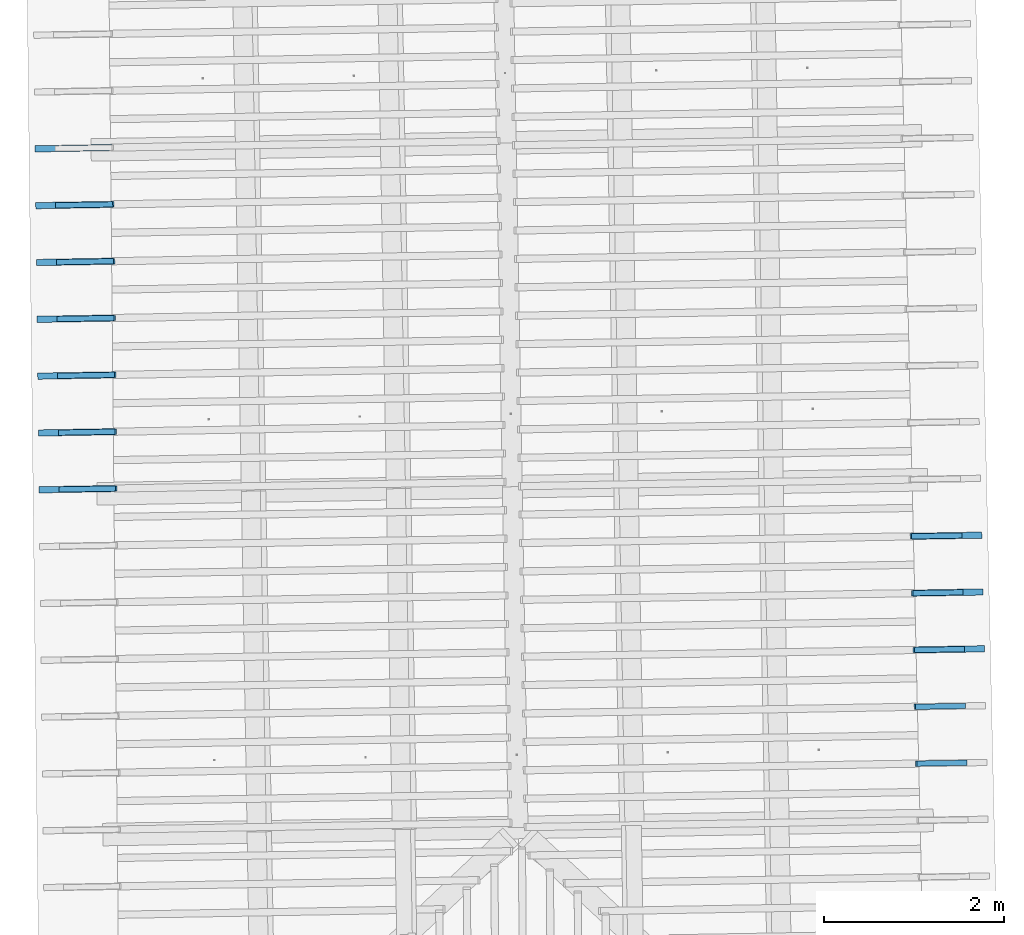
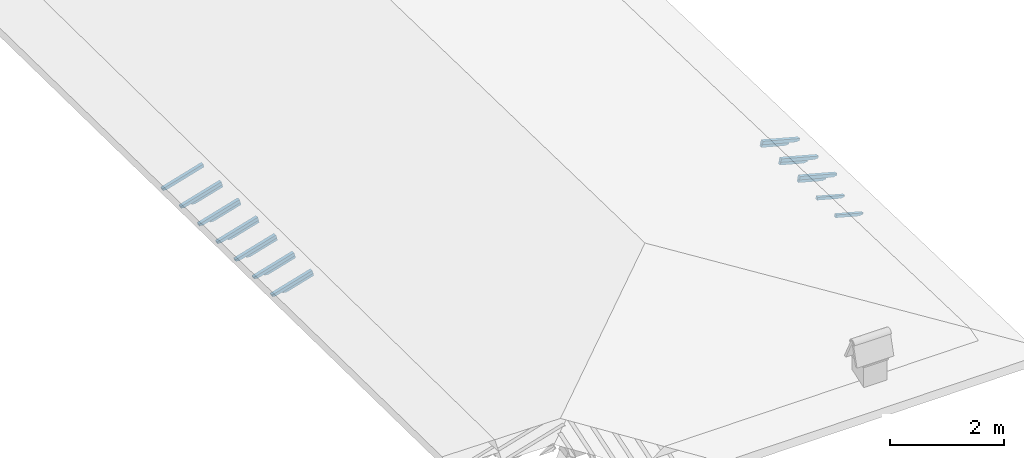
# One storey, part 12 of 19: 21 beams, 4 elements without a shape of their own.
"""IFC4 building model written with IfcOpenShell, lengths in metres."""

from ifc_helpers import new_model, entity, si_unit, converted_unit, derived_unit, direction, frame, origin, place, context, subcontext, project, spatial, line, arc, indexed_curve, outline, extrude, source, transform, mapped, material, type_object, type_shapes, element, aggregate, save


model = new_model("IFC4")

# Units and contexts
model_context = context("Model", 3, precision=1e-05, world=origin(), true_north=direction((6.123233995736766e-17, 1.0)))
body_context = subcontext(model_context, "Body", "Model", "MODEL_VIEW")
ifc_project = project(units=[si_unit("LENGTHUNIT", "METRE"), si_unit("AREAUNIT", "SQUARE_METRE"), si_unit("VOLUMEUNIT", "CUBIC_METRE"), converted_unit("PLANEANGLEUNIT", "DEGREE", entity("IfcPlaneAngleMeasure", 0.017453292519943278), si_unit("PLANEANGLEUNIT", "RADIAN"), dimensions=[0, 0, 0, 0, 0, 0, 0]), derived_unit("THERMALTRANSMITTANCEUNIT", [(si_unit("MASSUNIT", "GRAM", prefix="KILO"), 1), (si_unit("THERMODYNAMICTEMPERATUREUNIT", "KELVIN"), -1), (si_unit("TIMEUNIT", "SECOND"), -3)])], contexts=[model_context])

# Site, building, storey
site_placement = place(None, origin())
site = spatial("IfcSite", under=ifc_project, at=site_placement, CompositionType="ELEMENT")
building_placement = place(site_placement, origin())
building = spatial("IfcBuilding", under=site, at=building_placement, CompositionType="ELEMENT")
storey_placement = place(building_placement, frame((0.0, 0.0, 3.28)))
storey = spatial("IfcBuildingStorey", under=building, at=storey_placement, Name="Livello Copertura", CompositionType="ELEMENT", Elevation=3.28)

# Assembly, beams
assembly_1_placement = place(storey_placement, origin())
assembly_1 = element("IfcElementAssembly", 1, at=assembly_1_placement, inside=storey, Name="Sistema di travi strutturali:Sistema di travi strutturali", ObjectType="Sistema di travi strutturali:Sistema di travi strutturali", AssemblyPlace="NOTDEFINED", PredefinedType="BEAM_GRID")
ifc_material = material(Name="Legno - Legno da costruzione", Category="Legno")
beam_type_1 = type_object("IfcBeamType", Name="70x70:70x70", PredefinedType="JOIST", material=ifc_material)
shared_shape_1 = source(origin(), body_context, "Body", "SweptSolid", [
    extrude(outline(indexed_curve([(-0.04357142857143152, -0.5797142857142852), (0.02642857142856847, -0.5797142857142852), (0.02642857142856847, 0.18228571428571472), (0.012428571428584355, 0.18228571428571133), (0.026181867029378872, 0.20599531881361596), (0.018428571428570784, 0.23228571428571498), (0.006014118110847748, 0.2552812898006979), (0.003428571428570958, 0.2812857142857148), (-0.04357142857143152, 0.2812857142857147)], segments=[line(1, 2, 3, 4), arc(4, 5, 6), arc(6, 7, 8), line(8, 9, 1)], self_intersect=False)), frame((-0.11421428571428516, -0.03500000000000078, -0.008571428571433256), z_axis=(0.0, 1.0, 0.0), x_axis=(0.0, 0.0, -1.0)), (0.0, 0.0, 1.0), 0.06999999999999999),
])
type_shapes(beam_type_1, [shared_shape_1])
beam_1_placement = place(assembly_1_placement, frame((-5.029405355728567, 4.698225552128371, 0.10493046016911012), z_axis=(-0.2688805697492532, -0.004594467440668782, 0.9631625667976583), x_axis=(0.9630219859926786, 0.016455533263033555, 0.26891982061526515)))
beam_1 = element("IfcBeam", 2, at=beam_1_placement, type_object=beam_type_1, material=ifc_material, Name="70x70:70x70", ObjectType="70x70:70x70", PredefinedType="JOIST", context=body_context, shape_type="MappedRepresentation", body=[
    mapped(shared_shape_1, transform((0.0, 0.0, 0.0), scale=1.0)),
])
beam_type_2 = type_object("IfcBeamType", Name="70x70:70x70", PredefinedType="JOIST", material=ifc_material)
shared_shape_2 = source(origin(), body_context, "Body", "SweptSolid", [
    extrude(outline(indexed_curve([(-0.04357142857143151, -0.580428571428571), (0.026428571428568484, -0.580428571428571), (0.026428571428568484, 0.1825714285714291), (0.012428571428584384, 0.18257142857142572), (0.026181867029378903, 0.20628103309933035), (0.01842857142857075, 0.23257142857142923), (0.006014118110847714, 0.25556700408641214), (0.0034285714285709197, 0.2815714285714291), (-0.04357142857143151, 0.2815714285714291)], segments=[line(1, 2, 3, 4), arc(4, 5, 6), arc(6, 7, 8), line(8, 9, 1)], self_intersect=False)), frame((-0.11442857142857095, -0.03500000000000078, -0.008571428571433238), z_axis=(0.0, 1.0, 0.0), x_axis=(0.0, 0.0, -1.0)), (0.0, 0.0, 1.0), 0.06999999999999999),
])
type_shapes(beam_type_2, [shared_shape_2])
beam_2_placement = place(assembly_1_placement, frame((-5.0361867308732124, 5.328201642770682, 0.10604244755441838), z_axis=(-0.26888056974925356, -0.0045944674406687884, 0.9631625667976582), x_axis=(0.9630219859926786, 0.016455533263033, 0.26891982061526554)))
beam_2 = element("IfcBeam", 3, at=beam_2_placement, type_object=beam_type_2, material=ifc_material, Name="70x70:70x70", ObjectType="70x70:70x70", PredefinedType="JOIST", context=body_context, shape_type="MappedRepresentation", body=[
    mapped(shared_shape_2, transform((0.0, 0.0, 0.0), scale=1.0)),
])
beam_type_3 = type_object("IfcBeamType", Name="70x70:70x70", PredefinedType="JOIST", material=ifc_material)
shared_shape_3 = source(origin(), body_context, "Body", "SweptSolid", [
    extrude(outline(indexed_curve([(-0.04357142857143151, -0.5811428571428567), (0.026428571428568484, -0.5811428571428567), (0.026428571428568484, 0.18285714285714338), (0.012428571428584384, 0.18285714285714), (0.026181867029378903, 0.20656674738504463), (0.01842857142857075, 0.2328571428571435), (0.006014118110847714, 0.2558527183721264), (0.0034285714285709197, 0.28185714285714336), (-0.04357142857143151, 0.28185714285714336)], segments=[line(1, 2, 3, 4), arc(4, 5, 6), arc(6, 7, 8), line(8, 9, 1)], self_intersect=False)), frame((-0.11464285714285669, -0.03500000000000078, -0.008571428571433238), z_axis=(0.0, 1.0, 0.0), x_axis=(0.0, 0.0, -1.0)), (0.0, 0.0, 1.0), 0.06999999999999999),
])
type_shapes(beam_type_3, [shared_shape_3])
beam_3_placement = place(assembly_1_placement, frame((-5.042968106017856, 5.958177733412997, 0.10715443493972887), z_axis=(-0.268880569749253, -0.0045944674406687815, 0.9631625667976584), x_axis=(0.9630219859926786, 0.016455533263033662, 0.2689198206152649)))
beam_3 = element("IfcBeam", 4, at=beam_3_placement, type_object=beam_type_3, material=ifc_material, Name="70x70:70x70", ObjectType="70x70:70x70", PredefinedType="JOIST", context=body_context, shape_type="MappedRepresentation", body=[
    mapped(shared_shape_3, transform((0.0, 0.0, 0.0), scale=1.0)),
])
beam_type_4 = type_object("IfcBeamType", Name="70x70:70x70", PredefinedType="JOIST", material=ifc_material)
shared_shape_4 = source(origin(), body_context, "Body", "SweptSolid", [
    extrude(outline(indexed_curve([(-0.04357142857143144, -0.5825714285714283), (0.02642857142856855, -0.5825714285714283), (0.02642857142856855, 0.18342857142857197), (0.012428571428584454, 0.18342857142856858), (0.02618186702937897, 0.20713817595647321), (0.01842857142857058, 0.2334285714285721), (0.006014118110847545, 0.25642414694355503), (0.0034285714285707506, 0.2824285714285719), (-0.04357142857143144, 0.2824285714285719)], segments=[line(1, 2, 3, 4), arc(4, 5, 6), arc(6, 7, 8), line(8, 9, 1)], self_intersect=False)), frame((-0.11507142857142813, -0.03500000000000078, -0.00857142857143317), z_axis=(0.0, 1.0, 0.0), x_axis=(0.0, 0.0, -1.0)), (0.0, 0.0, 1.0), 0.06999999999999999),
])
type_shapes(beam_type_4, [shared_shape_4])
beam_4_placement = place(assembly_1_placement, frame((-5.049749481162497, 6.588153824055307, 0.10826642232503736), z_axis=(-0.26888056974925384, -0.0045944674406687945, 0.9631625667976582), x_axis=(0.9630219859926784, 0.016455533263033142, 0.26891982061526576)))
beam_4 = element("IfcBeam", 5, at=beam_4_placement, type_object=beam_type_4, material=ifc_material, Name="70x70:70x70", ObjectType="70x70:70x70", PredefinedType="JOIST", context=body_context, shape_type="MappedRepresentation", body=[
    mapped(shared_shape_4, transform((0.0, 0.0, 0.0), scale=1.0)),
])
beam_type_5 = type_object("IfcBeamType", Name="70x70:70x70", PredefinedType="JOIST", material=ifc_material)
shared_shape_5 = source(origin(), body_context, "Body", "SweptSolid", [
    extrude(outline(indexed_curve([(-0.04357142857143152, -0.5832857142857139), (0.026428571428568467, -0.5832857142857139), (0.026428571428568467, 0.1837142857142862), (0.012428571428584367, 0.1837142857142828), (0.026181867029378882, 0.20742389024218744), (0.018428571428570798, 0.23371428571428632), (0.006014118110847763, 0.25670986122926925), (0.0034285714285709687, 0.28271428571428614), (-0.04357142857143152, 0.28271428571428614)], segments=[line(1, 2, 3, 4), arc(4, 5, 6), arc(6, 7, 8), line(8, 9, 1)], self_intersect=False)), frame((-0.1152857142857138, -0.03500000000000078, -0.008571428571433257), z_axis=(0.0, 1.0, 0.0), x_axis=(0.0, 0.0, -1.0)), (0.0, 0.0, 1.0), 0.06999999999999999),
])
type_shapes(beam_type_5, [shared_shape_5])
beam_5_placement = place(assembly_1_placement, frame((-5.056530856307142, 7.218129914697621, 0.10937840971034651), z_axis=(-0.2688805697492532, -0.004594467440668782, 0.9631625667976583), x_axis=(0.9630219859926786, 0.016455533263033752, 0.26891982061526515)))
beam_5 = element("IfcBeam", 6, at=beam_5_placement, type_object=beam_type_5, material=ifc_material, Name="70x70:70x70", ObjectType="70x70:70x70", PredefinedType="JOIST", context=body_context, shape_type="MappedRepresentation", body=[
    mapped(shared_shape_5, transform((0.0, 0.0, 0.0), scale=1.0)),
])
beam_type_6 = type_object("IfcBeamType", Name="70x70:70x70", PredefinedType="JOIST", material=ifc_material)
shared_shape_6 = source(origin(), body_context, "Body", "SweptSolid", [
    extrude(outline(indexed_curve([(-0.043571428571431516, -0.5839999999999995), (0.026428571428568474, -0.5839999999999995), (0.026428571428568474, 0.18400000000000047), (0.012428571428584377, 0.18399999999999708), (0.026181867029378893, 0.20770960452790171), (0.018428571428570774, 0.23400000000000062), (0.006014118110847739, 0.25699557551498353), (0.0034285714285709444, 0.2830000000000004), (-0.043571428571431516, 0.2830000000000004)], segments=[line(1, 2, 3, 4), arc(4, 5, 6), arc(6, 7, 8), line(8, 9, 1)], self_intersect=False)), frame((-0.11549999999999952, -0.03500000000000078, -0.008571428571433249), z_axis=(0.0, 1.0, 0.0), x_axis=(0.0, 0.0, -1.0)), (0.0, 0.0, 1.0), 0.06999999999999999),
])
type_shapes(beam_type_6, [shared_shape_6])
beam_6_placement = place(assembly_1_placement, frame((-5.0633122314517856, 7.848106005339932, 0.11049039709565456), z_axis=(-0.26888056974925295, -0.004594467440668778, 0.9631625667976584), x_axis=(0.9630219859926787, 0.016455533263033235, 0.2689198206152649)))
beam_6 = element("IfcBeam", 7, at=beam_6_placement, type_object=beam_type_6, material=ifc_material, Name="70x70:70x70", ObjectType="70x70:70x70", PredefinedType="JOIST", context=body_context, shape_type="MappedRepresentation", body=[
    mapped(shared_shape_6, transform((0.0, 0.0, 0.0), scale=1.0)),
])
beam_type_7 = type_object("IfcBeamType", Name="70x70:70x70", PredefinedType="JOIST", material=ifc_material)
shared_shape_7 = source(origin(), body_context, "Body", "SweptSolid", [
    extrude(outline(indexed_curve([(-0.0435714285714315, -0.5847142857142853), (0.02642857142856849, -0.5847142857142853), (0.02642857142856849, 0.1842857142857148), (0.012428571428584397, 0.18428571428571142), (0.026181867029378917, 0.20799531881361605), (0.018428571428570725, 0.23428571428571493), (0.006014118110847691, 0.25728128980069787), (0.0034285714285708967, 0.28328571428571475), (-0.0435714285714315, 0.28328571428571475)], segments=[line(1, 2, 3, 4), arc(4, 5, 6), arc(6, 7, 8), line(8, 9, 1)], self_intersect=False)), frame((-0.11571428571428523, -0.03500000000000078, -0.008571428571433228), z_axis=(0.0, 1.0, 0.0), x_axis=(0.0, 0.0, -1.0)), (0.0, 0.0, 1.0), 0.06999999999999999),
])
type_shapes(beam_type_7, [shared_shape_7])
beam_7_placement = place(assembly_1_placement, frame((-5.07009360659643, 8.478082095982247, 0.11160238448096393), z_axis=(-0.2688805697492534, -0.004594467440668786, 0.9631625667976583), x_axis=(0.9630219859926785, 0.016455533263032736, 0.2689198206152653)))
beam_7 = element("IfcBeam", 8, at=beam_7_placement, type_object=beam_type_7, material=ifc_material, Name="70x70:70x70", ObjectType="70x70:70x70", PredefinedType="JOIST", context=body_context, shape_type="MappedRepresentation", body=[
    mapped(shared_shape_7, transform((0.0, 0.0, 0.0), scale=1.0)),
])
aggregate(assembly_1, [beam_1, beam_2, beam_3, beam_4, beam_5, beam_6, beam_7])

assembly_2_placement = place(storey_placement, origin())
assembly_2 = element("IfcElementAssembly", 9, at=assembly_2_placement, inside=storey, Name="Sistema di travi strutturali:Sistema di travi strutturali", ObjectType="Sistema di travi strutturali:Sistema di travi strutturali", AssemblyPlace="NOTDEFINED", PredefinedType="BEAM_GRID")
beam_type_8 = type_object("IfcBeamType", Name="60x60:60x60", PredefinedType="JOIST", material=ifc_material)
shared_shape_8 = source(origin(), body_context, "Body", "SweptSolid", [
    extrude(outline(indexed_curve([(-0.03585714285711767, -0.4284285714285716), (0.024142857142882314, -0.4284285714285716), (0.024142857142882314, 0.12357142857142843), (0.007142857142882376, 0.12357142857142843), (0.02280031419839931, 0.14116784462699616), (0.020142857142793777, 0.16457142857142956), (0.006097362558744978, 0.19272501701940936), (-0.003857142857205439, 0.2225714285714284), (-0.03585714285711767, 0.22257142857142848)], segments=[line(1, 2, 3, 4), arc(4, 5, 6), arc(6, 7, 8), line(8, 9, 1)], self_intersect=False)), frame((0.03707142857142847, -0.030000000000000786, -0.005857142857119404), z_axis=(0.0, 1.0, 0.0), x_axis=(0.0, 0.0, -1.0)), (0.0, 0.0, 1.0), 0.059999999999999984),
])
type_shapes(beam_type_8, [shared_shape_8])
beam_8_placement = place(assembly_2_placement, frame((-5.011928118694866, 4.698524192512016, 0.04232489332726197), z_axis=(-0.2688805697492532, -0.004594467440668782, 0.9631625667976583), x_axis=(0.9630219859926786, 0.016455533263033555, 0.26891982061526515)))
beam_8 = element("IfcBeam", 10, at=beam_8_placement, type_object=beam_type_8, material=ifc_material, Name="60x60:60x60", ObjectType="60x60:60x60", PredefinedType="JOIST", context=body_context, shape_type="MappedRepresentation", body=[
    mapped(shared_shape_8, transform((0.0, 0.0, 0.0), scale=1.0)),
])
beam_type_9 = type_object("IfcBeamType", Name="60x60:60x60", PredefinedType="JOIST", material=ifc_material)
shared_shape_9 = source(origin(), body_context, "Body", "SweptSolid", [
    extrude(outline(indexed_curve([(-0.03585714285711793, -0.4291428571428574), (0.02414285714288205, -0.4291428571428574), (0.02414285714288205, 0.12385714285714272), (0.007142857142882115, 0.12385714285714272), (0.022800314198399046, 0.14145355891271047), (0.02014285714279443, 0.16485714285714387), (0.00609736255874563, 0.19301073130512364), (-0.003857142857204787, 0.2228571428571427), (-0.03585714285711793, 0.22285714285714275)], segments=[line(1, 2, 3, 4), arc(4, 5, 6), arc(6, 7, 8), line(8, 9, 1)], self_intersect=False)), frame((0.03685714285714274, -0.030000000000000786, -0.005857142857119665), z_axis=(0.0, 1.0, 0.0), x_axis=(0.0, 0.0, -1.0)), (0.0, 0.0, 1.0), 0.059999999999999984),
])
type_shapes(beam_type_9, [shared_shape_9])
beam_9_placement = place(assembly_2_placement, frame((-5.01870949383951, 5.328500283154325, 0.04343688071257046), z_axis=(-0.26888056974925356, -0.0045944674406687884, 0.9631625667976582), x_axis=(0.9630219859926786, 0.016455533263033, 0.26891982061526554)))
beam_9 = element("IfcBeam", 11, at=beam_9_placement, type_object=beam_type_9, material=ifc_material, Name="60x60:60x60", ObjectType="60x60:60x60", PredefinedType="JOIST", context=body_context, shape_type="MappedRepresentation", body=[
    mapped(shared_shape_9, transform((0.0, 0.0, 0.0), scale=1.0)),
])
beam_type_10 = type_object("IfcBeamType", Name="60x60:60x60", PredefinedType="JOIST", material=ifc_material)
shared_shape_10 = source(origin(), body_context, "Body", "SweptSolid", [
    extrude(outline(indexed_curve([(-0.0358571428571179, -0.42985714285714316), (0.02414285714288208, -0.42985714285714316), (0.02414285714288208, 0.12414285714285703), (0.007142857142882144, 0.12414285714285703), (0.022800314198399077, 0.14173927319842475), (0.020142857142794356, 0.16514285714285817), (0.006097362558745559, 0.19329644559083797), (-0.0038571428572048583, 0.22314285714285698), (-0.0358571428571179, 0.22314285714285703)], segments=[line(1, 2, 3, 4), arc(4, 5, 6), arc(6, 7, 8), line(8, 9, 1)], self_intersect=False)), frame((0.03664285714285702, -0.030000000000000786, -0.005857142857119636), z_axis=(0.0, 1.0, 0.0), x_axis=(0.0, 0.0, -1.0)), (0.0, 0.0, 1.0), 0.059999999999999984),
])
type_shapes(beam_type_10, [shared_shape_10])
beam_10_placement = place(assembly_2_placement, frame((-5.025490868984154, 5.958476373796641, 0.04454886809788072), z_axis=(-0.268880569749253, -0.0045944674406687815, 0.9631625667976584), x_axis=(0.9630219859926786, 0.016455533263033662, 0.2689198206152649)))
beam_10 = element("IfcBeam", 12, at=beam_10_placement, type_object=beam_type_10, material=ifc_material, Name="60x60:60x60", ObjectType="60x60:60x60", PredefinedType="JOIST", context=body_context, shape_type="MappedRepresentation", body=[
    mapped(shared_shape_10, transform((0.0, 0.0, 0.0), scale=1.0)),
])
beam_type_11 = type_object("IfcBeamType", Name="60x60:60x60", PredefinedType="JOIST", material=ifc_material)
shared_shape_11 = source(origin(), body_context, "Body", "SweptSolid", [
    extrude(outline(indexed_curve([(-0.03585714285711788, -0.4312857142857146), (0.024142857142882102, -0.4312857142857146), (0.024142857142882102, 0.12471428571428562), (0.007142857142882163, 0.12471428571428562), (0.022800314198399098, 0.14231070176985336), (0.020142857142794308, 0.16571428571428676), (0.006097362558745509, 0.19386787416226653), (-0.0038571428572049074, 0.2237142857142856), (-0.03585714285711788, 0.22371428571428564)], segments=[line(1, 2, 3, 4), arc(4, 5, 6), arc(6, 7, 8), line(8, 9, 1)], self_intersect=False)), frame((0.036214285714285574, -0.030000000000000786, -0.005857142857119617), z_axis=(0.0, 1.0, 0.0), x_axis=(0.0, 0.0, -1.0)), (0.0, 0.0, 1.0), 0.059999999999999984),
])
type_shapes(beam_type_11, [shared_shape_11])
beam_11_placement = place(assembly_2_placement, frame((-5.032272244128797, 6.5884524644389515, 0.04566085548318943), z_axis=(-0.26888056974925384, -0.0045944674406687945, 0.9631625667976582), x_axis=(0.9630219859926784, 0.016455533263033142, 0.26891982061526576)))
beam_11 = element("IfcBeam", 13, at=beam_11_placement, type_object=beam_type_11, material=ifc_material, Name="60x60:60x60", ObjectType="60x60:60x60", PredefinedType="JOIST", context=body_context, shape_type="MappedRepresentation", body=[
    mapped(shared_shape_11, transform((0.0, 0.0, 0.0), scale=1.0)),
])
beam_type_12 = type_object("IfcBeamType", Name="60x60:60x60", PredefinedType="JOIST", material=ifc_material)
shared_shape_12 = source(origin(), body_context, "Body", "SweptSolid", [
    extrude(outline(indexed_curve([(-0.03585714285711779, -0.43200000000000016), (0.024142857142882196, -0.43200000000000016), (0.024142857142882196, 0.12499999999999985), (0.00714285714288226, 0.12499999999999985), (0.02280031419839919, 0.14259641605556758), (0.020142857142794065, 0.16600000000000098), (0.006097362558745267, 0.19415358844798075), (-0.0038571428572051493, 0.2239999999999998), (-0.03585714285711779, 0.22399999999999987)], segments=[line(1, 2, 3, 4), arc(4, 5, 6), arc(6, 7, 8), line(8, 9, 1)], self_intersect=False)), frame((0.03599999999999991, -0.030000000000000786, -0.00585714285711952), z_axis=(0.0, 1.0, 0.0), x_axis=(0.0, 0.0, -1.0)), (0.0, 0.0, 1.0), 0.059999999999999984),
])
type_shapes(beam_type_12, [shared_shape_12])
beam_12_placement = place(assembly_2_placement, frame((-5.039053619273441, 7.218428555081265, 0.04677284286849814), z_axis=(-0.2688805697492532, -0.004594467440668782, 0.9631625667976583), x_axis=(0.9630219859926786, 0.016455533263033752, 0.26891982061526515)))
beam_12 = element("IfcBeam", 14, at=beam_12_placement, type_object=beam_type_12, material=ifc_material, Name="60x60:60x60", ObjectType="60x60:60x60", PredefinedType="JOIST", context=body_context, shape_type="MappedRepresentation", body=[
    mapped(shared_shape_12, transform((0.0, 0.0, 0.0), scale=1.0)),
])
beam_type_13 = type_object("IfcBeamType", Name="60x60:60x60", PredefinedType="JOIST", material=ifc_material)
shared_shape_13 = source(origin(), body_context, "Body", "SweptSolid", [
    extrude(outline(indexed_curve([(-0.035857142857117254, -0.4327142857142859), (0.024142857142882727, -0.4327142857142859), (0.024142857142882727, 0.12528571428571422), (0.007142857142882869, 0.12528571428571428), (0.022800314198399802, 0.142882130341282), (0.0201428571427927, 0.16628571428571517), (0.006097362558743903, 0.19443930273369495), (-0.0038571428572065137, 0.224285714285714), (-0.035857142857117254, 0.2242857142857142)], segments=[line(1, 2, 3, 4), arc(4, 5, 6), arc(6, 7, 8), line(8, 9, 1)], self_intersect=False)), frame((0.03578571428571412, -0.030000000000000786, -0.00585714285711899), z_axis=(0.0, 1.0, 0.0), x_axis=(0.0, 0.0, -1.0)), (0.0, 0.0, 1.0), 0.059999999999999984),
])
type_shapes(beam_type_13, [shared_shape_13])
beam_13_placement = place(assembly_2_placement, frame((-5.045834994418086, 7.8484046457235745, 0.04788483025380619), z_axis=(-0.26888056974925295, -0.004594467440668778, 0.9631625667976584), x_axis=(0.9630219859926787, 0.016455533263033235, 0.2689198206152649)))
beam_13 = element("IfcBeam", 15, at=beam_13_placement, type_object=beam_type_13, material=ifc_material, Name="60x60:60x60", ObjectType="60x60:60x60", PredefinedType="JOIST", context=body_context, shape_type="MappedRepresentation", body=[
    mapped(shared_shape_13, transform((0.0, 0.0, 0.0), scale=1.0)),
])
aggregate(assembly_2, [beam_8, beam_9, beam_10, beam_11, beam_12, beam_13])

assembly_3_placement = place(storey_placement, origin())
assembly_3 = element("IfcElementAssembly", 16, at=assembly_3_placement, inside=storey, Name="Sistema di travi strutturali:Sistema di travi strutturali", ObjectType="Sistema di travi strutturali:Sistema di travi strutturali", AssemblyPlace="NOTDEFINED", PredefinedType="BEAM_GRID")
beam_type_14 = type_object("IfcBeamType", Name="70x70:70x70", PredefinedType="JOIST", material=ifc_material)
shared_shape_14 = source(origin(), body_context, "Body", "SweptSolid", [
    extrude(outline(indexed_curve([(-0.04357142857143146, -0.5268571428571424), (0.026428571428568533, -0.5268571428571424), (0.026428571428568533, 0.16114285714285767), (0.012428571428584436, 0.16114285714285428), (0.026181867029378955, 0.18485246167075892), (0.018428571428570614, 0.2111428571428578), (0.006014118110847579, 0.2341384326578407), (0.0034285714285707844, 0.2601428571428576), (-0.04357142857143146, 0.2601428571428576)], segments=[line(1, 2, 3, 4), arc(4, 5, 6), arc(6, 7, 8), line(8, 9, 1)], self_intersect=False)), frame((-0.09835714285714238, -0.03500000000000078, -0.008571428571433188), z_axis=(0.0, 1.0, 0.0), x_axis=(0.0, 0.0, -1.0)), (0.0, 0.0, 1.0), 0.06999999999999999),
])
type_shapes(beam_type_14, [shared_shape_14])
beam_14_placement = place(assembly_3_placement, frame((4.676467380121404, 4.183071432131907, 0.10949700717344668), z_axis=(0.2688805697492536, 0.004594467440668776, 0.9631625667976582), x_axis=(-0.9630219859926785, -0.016455533263032226, 0.2689198206152656)))
beam_14 = element("IfcBeam", 17, at=beam_14_placement, type_object=beam_type_14, material=ifc_material, Name="70x70:70x70", ObjectType="70x70:70x70", PredefinedType="JOIST", context=body_context, shape_type="MappedRepresentation", body=[
    mapped(shared_shape_14, transform((0.0, 0.0, 0.0), scale=1.0)),
])
beam_15_placement = place(assembly_3_placement, frame((4.690915386697829, 3.5532263442188956, 0.1084681201245834), z_axis=(0.26888056974925323, 0.0045944674406687685, 0.9631625667976583), x_axis=(-0.9630219859926786, -0.01645553326303236, 0.26891982061526515)))
beam_15 = element("IfcBeam", 18, at=beam_15_placement, type_object=beam_type_14, material=ifc_material, Name="70x70:70x70", ObjectType="70x70:70x70", PredefinedType="JOIST", context=body_context, shape_type="MappedRepresentation", body=[
    mapped(shared_shape_14, transform((0.0, 0.0, 0.0), scale=1.0)),
])
beam_type_15 = type_object("IfcBeamType", Name="70x70:70x70", PredefinedType="JOIST", material=ifc_material)
shared_shape_15 = source(origin(), body_context, "Body", "SweptSolid", [
    extrude(outline(indexed_curve([(-0.043571428571431446, -0.5261428571428567), (0.026428571428568543, -0.5261428571428567), (0.026428571428568543, 0.16085714285714334), (0.012428571428584447, 0.16085714285714), (0.026181867029378966, 0.18456674738504464), (0.01842857142857059, 0.2108571428571435), (0.006014118110847556, 0.2338527183721264), (0.0034285714285707614, 0.2598571428571433), (-0.043571428571431446, 0.2598571428571433)], segments=[line(1, 2, 3, 4), arc(4, 5, 6), arc(6, 7, 8), line(8, 9, 1)], self_intersect=False)), frame((-0.09814285714285666, -0.03500000000000078, -0.008571428571433178), z_axis=(0.0, 1.0, 0.0), x_axis=(0.0, 0.0, -1.0)), (0.0, 0.0, 1.0), 0.06999999999999999),
])
type_shapes(beam_type_15, [shared_shape_15])
beam_16_placement = place(assembly_3_placement, frame((4.705363393274253, 2.923381256305881, 0.10743923307571968), z_axis=(0.26888056974925295, 0.004594467440668763, 0.9631625667976584), x_axis=(-0.9630219859926787, -0.016455533263032514, 0.2689198206152649)))
beam_16 = element("IfcBeam", 19, at=beam_16_placement, type_object=beam_type_15, material=ifc_material, Name="70x70:70x70", ObjectType="70x70:70x70", PredefinedType="JOIST", context=body_context, shape_type="MappedRepresentation", body=[
    mapped(shared_shape_15, transform((0.0, 0.0, 0.0), scale=1.0)),
])
aggregate(assembly_3, [beam_14, beam_15, beam_16])

assembly_4_placement = place(storey_placement, origin())
assembly_4 = element("IfcElementAssembly", 20, at=assembly_4_placement, inside=storey, Name="Sistema di travi strutturali:Sistema di travi strutturali", ObjectType="Sistema di travi strutturali:Sistema di travi strutturali", AssemblyPlace="NOTDEFINED", PredefinedType="BEAM_GRID")
beam_type_16 = type_object("IfcBeamType", Name="60x60:60x60", PredefinedType="JOIST", material=ifc_material)
shared_shape_16 = source(origin(), body_context, "Body", "SweptSolid", [
    extrude(outline(indexed_curve([(-0.03585714285711773, -0.3755714285714287), (0.024142857142882244, -0.3755714285714287), (0.024142857142882244, 0.10242857142857129), (0.007142857142882308, 0.10242857142857129), (0.022800314198399244, 0.120024987484139), (0.020142857142793947, 0.14342857142857243), (0.006097362558745147, 0.1715821598765522), (-0.00385714285720527, 0.20142857142857126), (-0.03585714285711773, 0.20142857142857132)], segments=[line(1, 2, 3, 4), arc(4, 5, 6), arc(6, 7, 8), line(8, 9, 1)], self_intersect=False)), frame((0.0529285714285713, -0.030000000000000786, -0.005857142857119472), z_axis=(0.0, 1.0, 0.0), x_axis=(0.0, 0.0, -1.0)), (0.0, 0.0, 1.0), 0.059999999999999984),
])
type_shapes(beam_type_16, [shared_shape_16])
beam_17_placement = place(assembly_4_placement, frame((4.658990143087703, 4.182772791748264, 0.0468914403315992), z_axis=(0.2688805697492532, 0.004594467440668768, 0.9631625667976583), x_axis=(-0.9630219859926786, -0.01645553326303224, 0.2689198206152651)))
beam_17 = element("IfcBeam", 21, at=beam_17_placement, type_object=beam_type_16, material=ifc_material, Name="60x60:60x60", ObjectType="60x60:60x60", PredefinedType="JOIST", context=body_context, shape_type="MappedRepresentation", body=[
    mapped(shared_shape_16, transform((0.0, 0.0, 0.0), scale=1.0)),
])
beam_18_placement = place(assembly_4_placement, frame((4.673438149664127, 3.552927703835252, 0.04586255328273592), z_axis=(0.2688805697492534, 0.004594467440668771, 0.9631625667976584), x_axis=(-0.9630219859926786, -0.016455533263031737, 0.2689198206152653)))
beam_18 = element("IfcBeam", 22, at=beam_18_placement, type_object=beam_type_16, material=ifc_material, Name="60x60:60x60", ObjectType="60x60:60x60", PredefinedType="JOIST", context=body_context, shape_type="MappedRepresentation", body=[
    mapped(shared_shape_16, transform((0.0, 0.0, 0.0), scale=1.0)),
])
beam_type_17 = type_object("IfcBeamType", Name="60x60:60x60", PredefinedType="JOIST", material=ifc_material)
shared_shape_17 = source(origin(), body_context, "Body", "SweptSolid", [
    extrude(outline(indexed_curve([(-0.03585714285711773, -0.374857142857143), (0.024142857142882244, -0.374857142857143), (0.024142857142882244, 0.10214285714285697), (0.007142857142882308, 0.10214285714285697), (0.022800314198399244, 0.11973927319842471), (0.020142857142793947, 0.1431428571428581), (0.006097362558745147, 0.1712964455908379), (-0.00385714285720527, 0.20114285714285693), (-0.03585714285711773, 0.201142857142857)], segments=[line(1, 2, 3, 4), arc(4, 5, 6), arc(6, 7, 8), line(8, 9, 1)], self_intersect=False)), frame((0.05314285714285701, -0.030000000000000786, -0.005857142857119472), z_axis=(0.0, 1.0, 0.0), x_axis=(0.0, 0.0, -1.0)), (0.0, 0.0, 1.0), 0.059999999999999984),
])
type_shapes(beam_type_17, [shared_shape_17])
beam_19_placement = place(assembly_4_placement, frame((4.687886156240551, 2.9230826159222376, 0.04483366623387197), z_axis=(0.26888056974925295, 0.004594467440668763, 0.9631625667976584), x_axis=(-0.9630219859926787, -0.016455533263032514, 0.2689198206152649)))
beam_19 = element("IfcBeam", 23, at=beam_19_placement, type_object=beam_type_17, material=ifc_material, Name="60x60:60x60", ObjectType="60x60:60x60", PredefinedType="JOIST", context=body_context, shape_type="MappedRepresentation", body=[
    mapped(shared_shape_17, transform((0.0, 0.0, 0.0), scale=1.0)),
])
beam_type_18 = type_object("IfcBeamType", Name="60x60:60x60", PredefinedType="JOIST", material=ifc_material)
shared_shape_18 = source(origin(), body_context, "Body", "SweptSolid", [
    extrude(outline(indexed_curve([(-0.03585714285711785, -0.3741428571428572), (0.024142857142882126, -0.3741428571428572), (0.024142857142882126, 0.10185714285714267), (0.007142857142882192, 0.10185714285714267), (0.022800314198399122, 0.11945355891271041), (0.02014285714279423, 0.14285714285714382), (0.0060973625587454365, 0.1710107313051236), (-0.00385714285720498, 0.20085714285714265), (-0.03585714285711785, 0.2008571428571427)], segments=[line(1, 2, 3, 4), arc(4, 5, 6), arc(6, 7, 8), line(8, 9, 1)], self_intersect=False)), frame((0.05335714285714274, -0.030000000000000786, -0.005857142857119588), z_axis=(0.0, 1.0, 0.0), x_axis=(0.0, 0.0, -1.0)), (0.0, 0.0, 1.0), 0.059999999999999984),
])
type_shapes(beam_type_18, [shared_shape_18])
beam_20_placement = place(assembly_4_placement, frame((4.702334162816974, 2.293237528009226, 0.04380477918500825), z_axis=(0.2688805697492536, 0.004594467440668777, 0.9631625667976582), x_axis=(-0.9630219859926785, -0.01645553326303237, 0.2689198206152656)))
beam_20 = element("IfcBeam", 24, at=beam_20_placement, type_object=beam_type_18, material=ifc_material, Name="60x60:60x60", ObjectType="60x60:60x60", PredefinedType="JOIST", context=body_context, shape_type="MappedRepresentation", body=[
    mapped(shared_shape_18, transform((0.0, 0.0, 0.0), scale=1.0)),
])
beam_type_19 = type_object("IfcBeamType", Name="60x60:60x60", PredefinedType="JOIST", material=ifc_material)
shared_shape_19 = source(origin(), body_context, "Body", "SweptSolid", [
    extrude(outline(indexed_curve([(-0.03585714285711785, -0.37342857142857155), (0.024142857142882126, -0.37342857142857155), (0.024142857142882126, 0.1015714285714284), (0.007142857142882192, 0.1015714285714284), (0.022800314198399122, 0.1191678446269961), (0.02014285714279423, 0.14257142857142951), (0.0060973625587454365, 0.17072501701940931), (-0.00385714285720498, 0.20057142857142835), (-0.03585714285711785, 0.20057142857142843)], segments=[line(1, 2, 3, 4), arc(4, 5, 6), arc(6, 7, 8), line(8, 9, 1)], self_intersect=False)), frame((0.053571428571428464, -0.030000000000000786, -0.005857142857119588), z_axis=(0.0, 1.0, 0.0), x_axis=(0.0, 0.0, -1.0)), (0.0, 0.0, 1.0), 0.059999999999999984),
])
type_shapes(beam_type_19, [shared_shape_19])
beam_21_placement = place(assembly_4_placement, frame((4.716782169393397, 1.663392440096214, 0.042775892136143634), z_axis=(0.26888056974925323, 0.00459446744066877, 0.9631625667976583), x_axis=(-0.9630219859926786, -0.016455533263032198, 0.26891982061526515)))
beam_21 = element("IfcBeam", 25, at=beam_21_placement, type_object=beam_type_19, material=ifc_material, Name="60x60:60x60", ObjectType="60x60:60x60", PredefinedType="JOIST", context=body_context, shape_type="MappedRepresentation", body=[
    mapped(shared_shape_19, transform((0.0, 0.0, 0.0), scale=1.0)),
])
aggregate(assembly_4, [beam_17, beam_18, beam_19, beam_20, beam_21])

save(model, "model.ifc")
